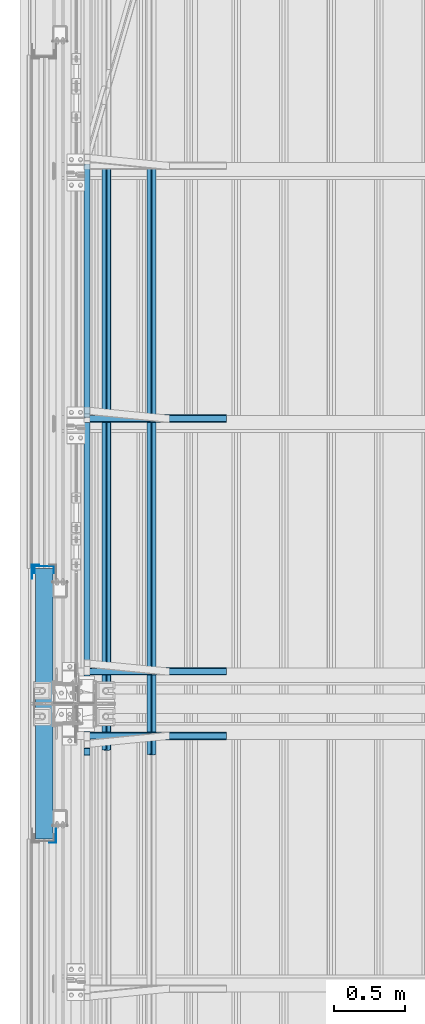
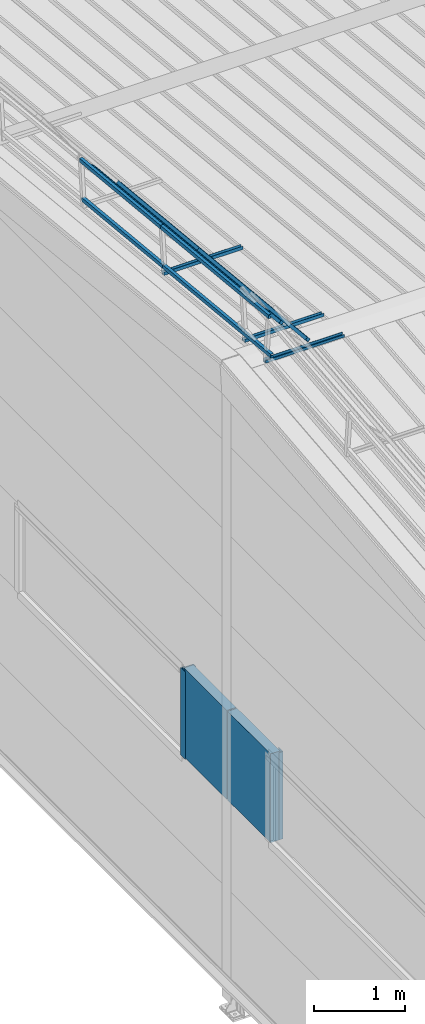
# One storey, part 39 of 709: 16 beams, 16 elements without a shape of their own.
"""IFC4 building model written with IfcOpenShell, lengths in millimetres."""

import ifcopenshell
import ifcopenshell.guid

model = None  # the IFC model being written
_history = None  # IfcOwnerHistory: only IFC2X3 demands one
_inside = {}  # id of a spatial element -> (the spatial element, [elements in it])
_under = {}  # id of a project, library or spatial element -> (it, [spatial elements below it])
_declared = {}  # id of a project -> (the project, [libraries it declares])
_typed = {}  # id of a type object -> (the type object, [elements of that type])
_made_of = {}  # id of a material, layer set ... -> (it, [elements and type objects made of it])


def new_model(schema):
    """Start an empty IFC model of exactly this schema.

    Asked for "IFC4X3", IfcOpenShell would pick the latest addendum, in which some entities
    have other attributes; the version numbers below select the first issue.
    IFC2X3 requires an IfcOwnerHistory on every rooted entity: one is made here for all.
    """
    global model, _history
    if schema == "IFC4X3":
        model = ifcopenshell.file(schema_version=(4, 3, 0, 0))
    else:
        model = ifcopenshell.file(schema=schema)
    _inside.clear()
    _under.clear()
    _declared.clear()
    _typed.clear()
    _made_of.clear()
    _history = None
    if model.schema == "IFC2X3":
        org = make("IfcOrganization", Name="unknown")
        user = make(
            "IfcPersonAndOrganization",
            ThePerson=make("IfcPerson", FamilyName="unknown"),
            TheOrganization=org,
        )
        app = make(
            "IfcApplication",
            ApplicationDeveloper=org,
            Version="unknown",
            ApplicationFullName="unknown",
            ApplicationIdentifier="unknown",
        )
        _history = make(
            "IfcOwnerHistory",
            OwningUser=user,
            OwningApplication=app,
            ChangeAction="ADDED",
            CreationDate=0,
        )
    return model


def make(cls, **values):
    """One entity of the class cls with the attributes given. An attribute that is None is left unset."""
    return model.create_entity(
        cls, **{name: value for name, value in values.items() if value is not None}
    )


def rooted(cls, **values):
    """An entity with a GlobalId (a new one), such as an element, a storey or a relation."""
    return make(cls, GlobalId=ifcopenshell.guid.new(), OwnerHistory=_history, **values)


def si_unit(unit_type, name, prefix=None):
    """IfcSIUnit, for example si_unit("LENGTHUNIT", "METRE", prefix="MILLI")."""
    return make("IfcSIUnit", UnitType=unit_type, Prefix=prefix, Name=name)


def assignment(units):
    """IfcUnitAssignment: the units of a project."""
    return None if units is None else make("IfcUnitAssignment", Units=units)


def point(xyz):
    """IfcCartesianPoint."""
    return None if xyz is None else make("IfcCartesianPoint", Coordinates=xyz)


def direction(xyz):
    """IfcDirection."""
    return None if xyz is None else make("IfcDirection", DirectionRatios=xyz)


def frame(location, z_axis=None, x_axis=None):
    """IfcAxis2Placement3D, a coordinate frame: its origin and axes. An axis left out is left unset."""
    return make(
        "IfcAxis2Placement3D",
        Location=point(location),
        Axis=direction(z_axis),
        RefDirection=direction(x_axis),
    )


def origin_with_axes():
    """The frame at (0, 0, 0) with the z axis (0, 0, 1) and the x axis (1, 0, 0) written out."""
    return frame((0.0, 0.0, 0.0), z_axis=(0.0, 0.0, 1.0), x_axis=(1.0, 0.0, 0.0))


def place(relative_to, where):
    """IfcLocalPlacement: puts the frame where relative to a parent placement (None: the world)."""
    return make(
        "IfcLocalPlacement", PlacementRelTo=relative_to, RelativePlacement=where
    )


def context(
    kind, dimensions, precision=None, world=None, true_north=None, identifier=None
):
    """IfcGeometricRepresentationContext, for example the 3D "Model" context."""
    return make(
        "IfcGeometricRepresentationContext",
        ContextIdentifier=identifier,
        ContextType=kind,
        CoordinateSpaceDimension=dimensions,
        Precision=precision,
        WorldCoordinateSystem=world,
        TrueNorth=true_north,
    )


def subcontext(parent, identifier, kind, view, scale=None):
    """IfcGeometricRepresentationSubContext, for example "Body" below "Model"."""
    return make(
        "IfcGeometricRepresentationSubContext",
        ContextIdentifier=identifier,
        ContextType=kind,
        ParentContext=parent,
        TargetScale=scale,
        TargetView=view,
    )


def project(units=None, contexts=None):
    """IfcProject with its units and contexts."""
    return rooted(
        "IfcProject",
        Name="project",
        RepresentationContexts=contexts,
        UnitsInContext=assignment(units),
    )


def spatial(cls, under=None, at=None, **own):
    """A site, building, storey or space (cls), placed at a placement, below another one or the project."""
    s = rooted(cls, ObjectPlacement=at, **own)
    if under is not None:
        _under.setdefault(under.id(), (under, []))[1].append(s)
    return s


def point_list(points):
    """IfcCartesianPointList2D or 3D."""
    cls = (
        "IfcCartesianPointList2D" if len(points[0]) == 2 else "IfcCartesianPointList3D"
    )
    return make(cls, CoordList=points)


def line(*indices):
    """IfcLineIndex: a straight run through numbered points of an indexed curve."""
    return model.create_entity("IfcLineIndex", indices)


def indexed_curve(points, segments=None, self_intersect=None):
    """IfcIndexedPolyCurve: lines and arcs through numbered points (the first is 1)."""
    return make(
        "IfcIndexedPolyCurve",
        Points=point_list(points),
        Segments=segments,
        SelfIntersect=self_intersect,
    )


def outline(outer, holes=None, kind="AREA"):
    """IfcArbitraryClosedProfileDef: a profile drawn as a closed curve; with holes, ...WithVoids."""
    if holes is None:
        return make("IfcArbitraryClosedProfileDef", ProfileType=kind, OuterCurve=outer)
    return make(
        "IfcArbitraryProfileDefWithVoids",
        ProfileType=kind,
        OuterCurve=outer,
        InnerCurves=holes,
    )


def extrude(swept, where, along, depth):
    """IfcExtrudedAreaSolid: the profile swept, set in the frame where, extruded along a direction by depth."""
    return make(
        "IfcExtrudedAreaSolid",
        SweptArea=swept,
        Position=where,
        ExtrudedDirection=direction(along),
        Depth=depth,
    )


def shape(context_of_items, identifier, shape_type, items):
    """IfcShapeRepresentation: the items that make up one representation, for example the "Body"."""
    return make(
        "IfcShapeRepresentation",
        ContextOfItems=context_of_items,
        RepresentationIdentifier=identifier,
        RepresentationType=shape_type,
        Items=items,
    )


def material(Name=None, Category=None):
    """IfcMaterial."""
    return make("IfcMaterial", Name=Name, Category=Category)


def made_of(thing, what):
    """Note that an element or type object is made of a material, layer set ...; save() writes the relation."""
    if what is not None:
        _made_of.setdefault(what.id(), (what, []))[1].append(thing)
    return thing


def element(
    cls,
    number,
    at=None,
    inside=None,
    cuts=None,
    type_object=None,
    material=None,
    context=None,
    identifier="Body",
    shape_type=None,
    held_by="IfcProductDefinitionShape",
    body=None,
    shapes=None,
    **own,
):
    """One element of the class cls, such as IfcWall. Its Tag is "e" and its number.

    at: its placement. inside: the storey or other place that contains it. cuts: it is an
    opening in that element (IfcRelVoidsElement). A single representation is given by context,
    identifier, shape_type and body (its items); several are given by shapes. held_by: the class
    of the entity that holds the representations. save() writes the other relations.
    """
    e = rooted(cls, Tag="e%d" % number, ObjectPlacement=at, **own)
    if body is not None:
        shapes = [shape(context, identifier, shape_type, body)]
    if shapes is not None:
        e.Representation = make(held_by, Representations=shapes)
    if inside is not None:
        _inside.setdefault(inside.id(), (inside, []))[1].append(e)
    if cuts is not None:
        rooted(
            "IfcRelVoidsElement", RelatingBuildingElement=cuts, RelatedOpeningElement=e
        )
    if type_object is not None:
        _typed.setdefault(type_object.id(), (type_object, []))[1].append(e)
    return made_of(e, material)


def aggregate(whole, parts):
    """IfcRelAggregates: a whole, such as a stair, and the parts it consists of."""
    return rooted("IfcRelAggregates", RelatingObject=whole, RelatedObjects=parts)


def save(model, path):
    """Write the relations noted so far, then the file.

    IfcRelAggregates (storeys below a building ...), IfcRelContainedInSpatialStructure (elements
    in a storey), IfcRelDefinesByType, IfcRelAssociatesMaterial and IfcRelDeclares: one each for
    every whole, place, type object, material and project.
    """
    for whole, parts in _under.values():
        aggregate(whole, parts)
    for where, things in _inside.values():
        rooted(
            "IfcRelContainedInSpatialStructure",
            RelatedElements=things,
            RelatingStructure=where,
        )
    for kind, things in _typed.values():
        rooted("IfcRelDefinesByType", RelatedObjects=things, RelatingType=kind)
    for what, things in _made_of.values():
        rooted("IfcRelAssociatesMaterial", RelatedObjects=things, RelatingMaterial=what)
    for by, libraries in _declared.values():
        rooted("IfcRelDeclares", RelatingContext=by, RelatedDefinitions=libraries)
    model.write(path)


model = new_model("IFC4")

# Units and contexts
model_context = context("Model", 3, precision=0.2, world=origin_with_axes(), true_north=direction((0.0, 1.0)))
body_context = subcontext(model_context, "Body", "Model", "MODEL_VIEW")
ifc_project = project(units=[si_unit("LENGTHUNIT", "METRE", prefix="MILLI"), si_unit("AREAUNIT", "SQUARE_METRE"), si_unit("VOLUMEUNIT", "CUBIC_METRE"), si_unit("MASSUNIT", "GRAM", prefix="KILO"), si_unit("TIMEUNIT", "SECOND"), si_unit("PLANEANGLEUNIT", "RADIAN"), si_unit("SOLIDANGLEUNIT", "STERADIAN"), si_unit("THERMODYNAMICTEMPERATUREUNIT", "DEGREE_CELSIUS"), si_unit("LUMINOUSINTENSITYUNIT", "LUMEN")], contexts=[model_context])

# Site, building, storey
site_placement = place(None, origin_with_axes())
site = spatial("IfcSite", under=ifc_project, at=site_placement, CompositionType="ELEMENT")
building_placement = place(site_placement, origin_with_axes())
building = spatial("IfcBuilding", under=site, at=building_placement, Name="Undefined", CompositionType="ELEMENT")
storey_placement = place(building_placement, origin_with_axes())
storey = spatial("IfcBuildingStorey", under=building, at=storey_placement, Name="Undefined", CompositionType="ELEMENT", Elevation=0.0)

# Assembly, beam
assembly_1_placement = place(storey_placement, frame((220.0, 10773.134, 8577.58301), z_axis=(0.0, -0.099503719, 0.9950371902), x_axis=(1.0, 0.0, 0.0)))
assembly_1 = element("IfcElementAssembly", 1, at=assembly_1_placement, inside=storey)
ifc_material_1 = material(Name="Steel_Undefined", Category="STEEL")
beam_1_placement = place(assembly_1_placement, origin_with_axes())
beam_1 = element("IfcBeam", 2, at=beam_1_placement, material=ifc_material_1, ObjectType="601", context=body_context, shape_type="SolidModel", body=[
    extrude(outline(indexed_curve([(-20.0, -25.0), (20.0, -25.0), (20.0, -22.5), (-17.5, -22.5), (-17.5, 22.5), (20.0, 22.5), (20.0, 25.0), (-20.0, 25.0)], segments=[line(1, 2, 3, 4, 5, 6, 7, 8, 1)])), frame((0.0, 0.0, 0.0), z_axis=(-1.0, 0.0, 0.0), x_axis=(0.0, 0.0, 1.0)), (0.0, 0.0, -1.0), 1000.0),
])
aggregate(assembly_1, [beam_1])

assembly_2_placement = place(storey_placement, frame((220.0, 11226.866, 8577.58301), z_axis=(0.0, 0.099503719, 0.9950371902), x_axis=(1.0, 0.0, 0.0)))
assembly_2 = element("IfcElementAssembly", 3, at=assembly_2_placement, inside=storey)
beam_2_placement = place(assembly_2_placement, origin_with_axes())
beam_2 = element("IfcBeam", 4, at=beam_2_placement, material=ifc_material_1, ObjectType="601", context=body_context, shape_type="SolidModel", body=[
    extrude(outline(indexed_curve([(-20.0, -25.0), (20.0, -25.0), (20.0, -22.5), (-17.5, -22.5), (-17.5, 22.5), (20.0, 22.5), (20.0, 25.0), (-20.0, 25.0)], segments=[line(1, 2, 3, 4, 5, 6, 7, 8, 1)])), frame((0.0, 0.0, 0.0), z_axis=(-1.0, 0.0, 0.0), x_axis=(0.0, 0.0, 1.0)), (0.0, 0.0, -1.0), 1000.0),
])
aggregate(assembly_2, [beam_2])

assembly_3_placement = place(storey_placement, frame((220.0, 13000.16625, 8400.25299), z_axis=(0.0, 0.099503719, 0.9950371902), x_axis=(1.0, 0.0, 0.0)))
assembly_3 = element("IfcElementAssembly", 5, at=assembly_3_placement, inside=storey)
beam_3_placement = place(assembly_3_placement, origin_with_axes())
beam_3 = element("IfcBeam", 6, at=beam_3_placement, material=ifc_material_1, ObjectType="601", context=body_context, shape_type="SolidModel", body=[
    extrude(outline(indexed_curve([(-20.0, -25.0), (20.0, -25.0), (20.0, -22.5), (-17.5, -22.5), (-17.5, 22.5), (20.0, 22.5), (20.0, 25.0), (-20.0, 25.0)], segments=[line(1, 2, 3, 4, 5, 6, 7, 8, 1)])), frame((0.0, 0.0, 0.0), z_axis=(-1.0, 0.0, 0.0), x_axis=(0.0, 0.0, 1.0)), (0.0, 0.0, -1.0), 1000.0),
])
aggregate(assembly_3, [beam_3])

assembly_4_placement = place(storey_placement, frame((240.0, 10687.55585, 9214.40681), z_axis=(1.0, 0.0, 0.0), x_axis=(0.0, 0.9950371902, -0.099503719)))
assembly_4 = element("IfcElementAssembly", 7, at=assembly_4_placement, inside=storey)
beam_4_placement = place(assembly_4_placement, origin_with_axes())
beam_4 = element("IfcBeam", 8, at=beam_4_placement, material=ifc_material_1, ObjectType="611", context=body_context, shape_type="SolidModel", body=[
    extrude(outline(indexed_curve([(-20.0, -25.0), (20.0, -25.0), (20.0, -22.5), (-17.5, -22.5), (-17.5, 22.5), (20.0, 22.5), (20.0, 25.0), (-20.0, 25.0)], segments=[line(1, 2, 3, 4, 5, 6, 7, 8, 1)])), frame((0.0, 0.0, 0.0), z_axis=(-1.0, 0.0, 0.0), x_axis=(0.0, 0.0, 1.0)), (0.0, 0.0, -1.0), 2382.14469),
])
aggregate(assembly_4, [beam_4])

assembly_5_placement = place(storey_placement, frame((240.0, 10637.80399, 8716.88822), z_axis=(1.0, 0.0, 0.0), x_axis=(0.0, 0.9950371902, -0.099503719)))
assembly_5 = element("IfcElementAssembly", 9, at=assembly_5_placement, inside=storey)
beam_5_placement = place(assembly_5_placement, origin_with_axes())
beam_5 = element("IfcBeam", 10, at=beam_5_placement, material=ifc_material_1, ObjectType="611", context=body_context, shape_type="SolidModel", body=[
    extrude(outline(indexed_curve([(-20.0, -25.0), (20.0, -25.0), (20.0, -22.5), (-17.5, -22.5), (-17.5, 22.5), (20.0, 22.5), (20.0, 25.0), (-20.0, 25.0)], segments=[line(1, 2, 3, 4, 5, 6, 7, 8, 1)])), frame((0.0, 0.0, 0.0), z_axis=(-1.0, 0.0, 0.0), x_axis=(0.0, 0.0, 1.0)), (0.0, 0.0, -1.0), 2382.14469),
])
aggregate(assembly_5, [beam_5])

assembly_6_placement = place(storey_placement, frame((375.56349, 10674.89109, 9087.75926), z_axis=(0.707106781, 0.070359754, 0.703597545), x_axis=(0.0, 0.9950371902, -0.099503719)))
assembly_6 = element("IfcElementAssembly", 11, at=assembly_6_placement, inside=storey)
beam_6_placement = place(assembly_6_placement, origin_with_axes())
beam_6 = element("IfcBeam", 12, at=beam_6_placement, material=ifc_material_1, ObjectType="611", context=body_context, shape_type="SolidModel", body=[
    extrude(outline(indexed_curve([(-20.0, -25.0), (20.0, -25.0), (20.0, -22.5), (-17.5, -22.5), (-17.5, 22.5), (20.0, 22.5), (20.0, 25.0), (-20.0, 25.0)], segments=[line(1, 2, 3, 4, 5, 6, 7, 8, 1)])), frame((0.0, 0.0, 0.0), z_axis=(-1.0, 0.0, 0.0), x_axis=(0.0, 0.0, 1.0)), (0.0, 0.0, -1.0), 2382.14469),
])
aggregate(assembly_6, [beam_6])

assembly_7_placement = place(storey_placement, frame((692.72078, 10643.33276, 8772.17596), z_axis=(0.707106781, 0.070359754, 0.703597545), x_axis=(0.0, 0.9950371902, -0.099503719)))
assembly_7 = element("IfcElementAssembly", 13, at=assembly_7_placement, inside=storey)
beam_7_placement = place(assembly_7_placement, origin_with_axes())
beam_7 = element("IfcBeam", 14, at=beam_7_placement, material=ifc_material_1, ObjectType="611", context=body_context, shape_type="SolidModel", body=[
    extrude(outline(indexed_curve([(-20.0, -25.0), (20.0, -25.0), (20.0, -22.5), (-17.5, -22.5), (-17.5, 22.5), (20.0, 22.5), (20.0, 25.0), (-20.0, 25.0)], segments=[line(1, 2, 3, 4, 5, 6, 7, 8, 1)])), frame((0.0, 0.0, 0.0), z_axis=(-1.0, 0.0, 0.0), x_axis=(0.0, 0.0, 1.0)), (0.0, 0.0, -1.0), 2382.14469),
])
aggregate(assembly_7, [beam_7])

assembly_8_placement = place(storey_placement, frame((240.0, 13057.87841, 8977.37456), z_axis=(1.0, 0.0, 0.0), x_axis=(0.0, 0.9950371902, -0.099503719)))
assembly_8 = element("IfcElementAssembly", 15, at=assembly_8_placement, inside=storey)
beam_8_placement = place(assembly_8_placement, origin_with_axes())
beam_8 = element("IfcBeam", 16, at=beam_8_placement, material=ifc_material_1, ObjectType="610", context=body_context, shape_type="SolidModel", body=[
    extrude(outline(indexed_curve([(-20.0, -25.0), (20.0, -25.0), (20.0, -22.5), (-17.5, -22.5), (-17.5, 22.5), (20.0, 22.5), (20.0, 25.0), (-20.0, 25.0)], segments=[line(1, 2, 3, 4, 5, 6, 7, 8, 1)])), frame((0.0, 0.0, 0.0), z_axis=(-1.0, 0.0, 0.0), x_axis=(0.0, 0.0, 1.0)), (0.0, 0.0, -1.0), 1782.14469),
])
aggregate(assembly_8, [beam_8])

assembly_9_placement = place(storey_placement, frame((240.0, 13008.12655, 8479.85596), z_axis=(1.0, 0.0, 0.0), x_axis=(0.0, 0.9950371902, -0.099503719)))
assembly_9 = element("IfcElementAssembly", 17, at=assembly_9_placement, inside=storey)
beam_9_placement = place(assembly_9_placement, origin_with_axes())
beam_9 = element("IfcBeam", 18, at=beam_9_placement, material=ifc_material_1, ObjectType="610", context=body_context, shape_type="SolidModel", body=[
    extrude(outline(indexed_curve([(-20.0, -25.0), (20.0, -25.0), (20.0, -22.5), (-17.5, -22.5), (-17.5, 22.5), (20.0, 22.5), (20.0, 25.0), (-20.0, 25.0)], segments=[line(1, 2, 3, 4, 5, 6, 7, 8, 1)])), frame((0.0, 0.0, 0.0), z_axis=(-1.0, 0.0, 0.0), x_axis=(0.0, 0.0, 1.0)), (0.0, 0.0, -1.0), 1782.14469),
])
aggregate(assembly_9, [beam_9])

assembly_10_placement = place(storey_placement, frame((375.56349, 13045.21365, 8850.727), z_axis=(0.707106781, 0.070359754, 0.703597545), x_axis=(0.0, 0.9950371902, -0.099503719)))
assembly_10 = element("IfcElementAssembly", 19, at=assembly_10_placement, inside=storey)
beam_10_placement = place(assembly_10_placement, origin_with_axes())
beam_10 = element("IfcBeam", 20, at=beam_10_placement, material=ifc_material_1, ObjectType="610", context=body_context, shape_type="SolidModel", body=[
    extrude(outline(indexed_curve([(-20.0, -25.0), (20.0, -25.0), (20.0, -22.5), (-17.5, -22.5), (-17.5, 22.5), (20.0, 22.5), (20.0, 25.0), (-20.0, 25.0)], segments=[line(1, 2, 3, 4, 5, 6, 7, 8, 1)])), frame((0.0, 0.0, 0.0), z_axis=(-1.0, 0.0, 0.0), x_axis=(0.0, 0.0, 1.0)), (0.0, 0.0, -1.0), 1782.14469),
])
aggregate(assembly_10, [beam_10])

assembly_11_placement = place(storey_placement, frame((692.72078, 13013.65532, 8535.1437), z_axis=(0.707106781, 0.070359754, 0.703597545), x_axis=(0.0, 0.9950371902, -0.099503719)))
assembly_11 = element("IfcElementAssembly", 21, at=assembly_11_placement, inside=storey)
beam_11_placement = place(assembly_11_placement, origin_with_axes())
beam_11 = element("IfcBeam", 22, at=beam_11_placement, material=ifc_material_1, ObjectType="610", context=body_context, shape_type="SolidModel", body=[
    extrude(outline(indexed_curve([(-20.0, -25.0), (20.0, -25.0), (20.0, -22.5), (-17.5, -22.5), (-17.5, 22.5), (20.0, 22.5), (20.0, 25.0), (-20.0, 25.0)], segments=[line(1, 2, 3, 4, 5, 6, 7, 8, 1)])), frame((0.0, 0.0, 0.0), z_axis=(-1.0, 0.0, 0.0), x_axis=(0.0, 0.0, 1.0)), (0.0, 0.0, -1.0), 1782.14469),
])
aggregate(assembly_11, [beam_11])

assembly_12_placement = place(storey_placement, frame((-60.0, 10050.0, 3275.0), z_axis=(0.0, 0.0, -1.0), x_axis=(0.0, 1.0, 0.0)))
assembly_12 = element("IfcElementAssembly", 23, at=assembly_12_placement, inside=storey)
ifc_material_2 = material(Name="Insulation", Category="Insulation")
beam_12_placement = place(assembly_12_placement, origin_with_axes())
beam_12 = element("IfcBeam", 24, at=beam_12_placement, material=ifc_material_2, ObjectType="P-138", context=body_context, shape_type="SolidModel", body=[
    extrude(outline(indexed_curve([(-595.0, -60.0), (595.0, -60.0), (595.0, 60.0), (-595.0, 60.0)], segments=[line(1, 2, 3, 4, 1)])), frame((0.0, 0.0, 0.0), z_axis=(-1.0, 0.0, 0.0), x_axis=(0.0, 0.0, 1.0)), (0.0, 0.0, -1.0), 940.0),
])
aggregate(assembly_12, [beam_12])

assembly_13_placement = place(storey_placement, frame((-60.0, 11010.0, 3275.0), z_axis=(0.0, 0.0, -1.0), x_axis=(0.0, 1.0, 0.0)))
assembly_13 = element("IfcElementAssembly", 25, at=assembly_13_placement, inside=storey)
beam_13_placement = place(assembly_13_placement, origin_with_axes())
beam_13 = element("IfcBeam", 26, at=beam_13_placement, material=ifc_material_2, ObjectType="P-138", context=body_context, shape_type="SolidModel", body=[
    extrude(outline(indexed_curve([(-595.0, -60.0), (595.0, -60.0), (595.0, 60.0), (-595.0, 60.0)], segments=[line(1, 2, 3, 4, 1)])), frame((0.0, 0.0, 0.0), z_axis=(-1.0, 0.0, 0.0), x_axis=(0.0, 0.0, 1.0)), (0.0, 0.0, -1.0), 940.0),
])
aggregate(assembly_13, [beam_13])

assembly_14_placement = place(storey_placement, frame((-1.0, 10025.0, 3870.0), z_axis=(1.0, 0.0, 0.0), x_axis=(0.0, 0.0, -1.0)))
assembly_14 = element("IfcElementAssembly", 27, at=assembly_14_placement, inside=storey)
beam_14_placement = place(assembly_14_placement, origin_with_axes())
beam_14 = element("IfcBeam", 28, at=beam_14_placement, material=ifc_material_1, context=body_context, shape_type="SolidModel", body=[
    extrude(outline(indexed_curve([(-25.0, -1.0), (25.0, -1.0), (25.0, 99.0), (23.0, 99.0), (23.0, 1.0), (-25.0, 1.0)], segments=[line(1, 2, 3, 4, 5, 6, 1)])), frame((0.0, 0.0, 0.0), z_axis=(-1.0, 0.0, 0.0), x_axis=(0.0, 0.0, 1.0)), (0.0, 0.0, -1.0), 1170.0),
])
aggregate(assembly_14, [beam_14])

assembly_15_placement = place(storey_placement, frame((-60.0, 11940.0, 3870.0), z_axis=(1.0, 0.0, 0.0), x_axis=(0.0, 0.0, -1.0)))
assembly_15 = element("IfcElementAssembly", 29, at=assembly_15_placement, inside=storey)
beam_15_placement = place(assembly_15_placement, origin_with_axes())
beam_15 = element("IfcBeam", 30, at=beam_15_placement, material=ifc_material_1, context=body_context, shape_type="SolidModel", body=[
    extrude(outline(indexed_curve([(-70.0, -25.0), (-68.0, -25.0), (-68.0, 23.0), (68.0, 23.0), (68.0, -25.0), (70.0, -25.0), (70.0, 25.0), (-70.0, 25.0)], segments=[line(1, 2, 3, 4, 5, 6, 7, 8, 1)])), frame((0.0, 0.0, 0.0), z_axis=(-1.0, 0.0, 0.0), x_axis=(0.0, 0.0, 1.0)), (0.0, 0.0, -1.0), 1170.0),
])
aggregate(assembly_15, [beam_15])

assembly_16_placement = place(storey_placement, frame((-121.0, 11975.0, 3870.0), z_axis=(-1.0, 0.0, 0.0), x_axis=(0.0, 0.0, -1.0)))
assembly_16 = element("IfcElementAssembly", 31, at=assembly_16_placement, inside=storey)
beam_16_placement = place(assembly_16_placement, origin_with_axes())
beam_16 = element("IfcBeam", 32, at=beam_16_placement, material=ifc_material_1, context=body_context, shape_type="SolidModel", body=[
    extrude(outline(indexed_curve([(-25.0, -1.0), (25.0, -1.0), (25.0, 99.0), (23.0, 99.0), (23.0, 1.0), (-25.0, 1.0)], segments=[line(1, 2, 3, 4, 5, 6, 1)])), frame((0.0, 0.0, 0.0), z_axis=(-1.0, 0.0, 0.0), x_axis=(0.0, 0.0, 1.0)), (0.0, 0.0, -1.0), 1170.0),
])
aggregate(assembly_16, [beam_16])

save(model, "model.ifc")
